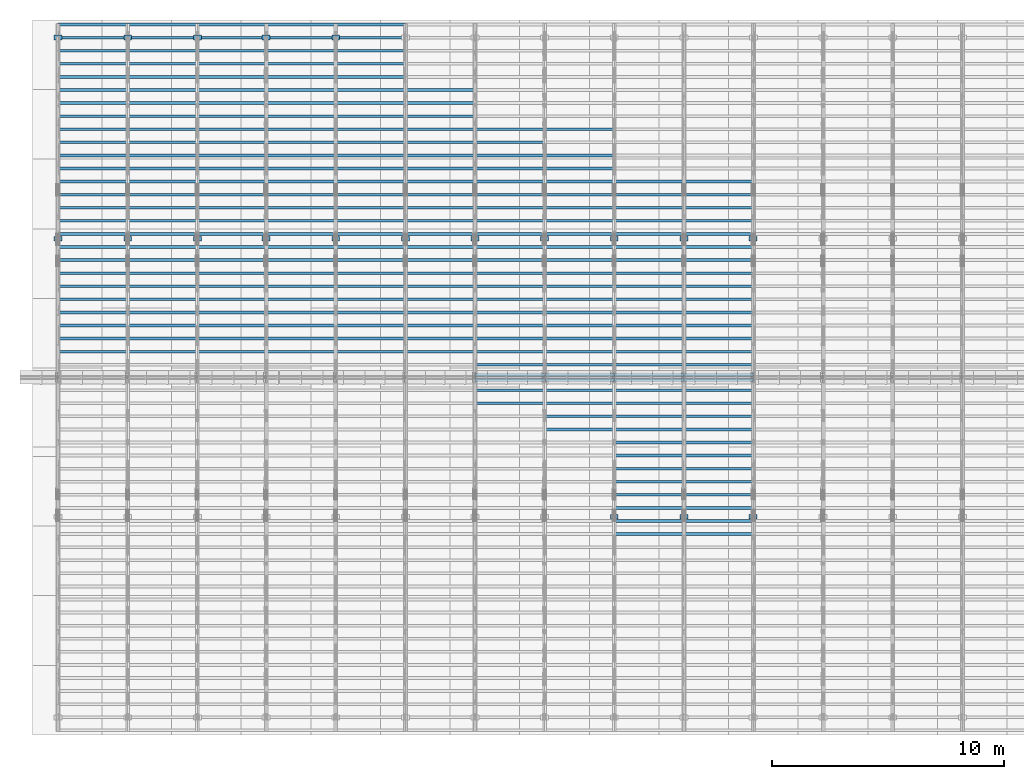
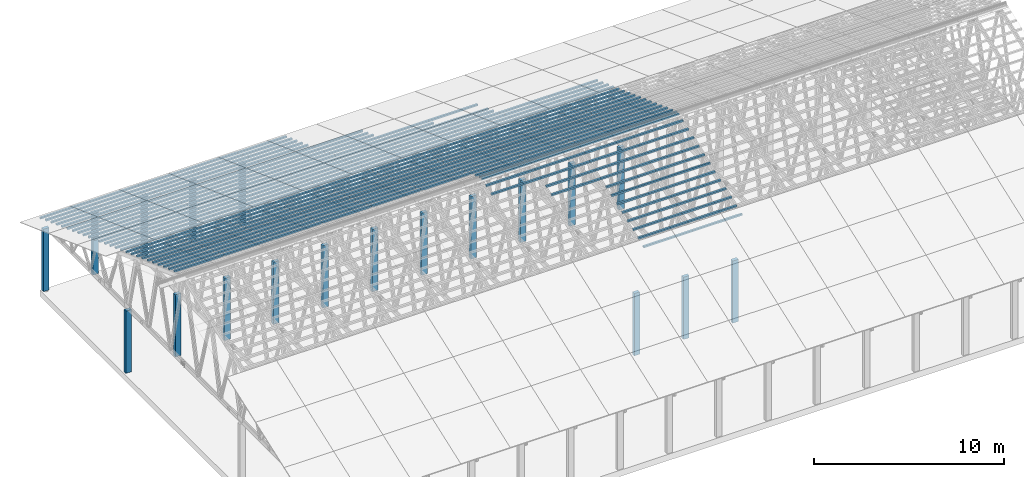
# One storey, part 2 of 189: 275 columns.
"""IFC2X3 building model written with IfcOpenShell, lengths in millimetres."""

from ifc_helpers import new_model, entity, si_unit, converted_unit, derived_unit, direction, frame, frame_2d, origin, origin_2d_with_axis, place, context, subcontext, project, spatial, rectangle, extrude, boolean, source, transform, mapped, material, type_object, type_shapes, element, save


model = new_model("IFC2X3")

# Units and contexts
model_context = context("Model", 3, precision=0.01, world=origin(), true_north=direction((6.12303176911189e-17, 1.0)))
body_context = subcontext(model_context, "Body", "Model", "MODEL_VIEW")
ifc_project = project(units=[si_unit("LENGTHUNIT", "METRE", prefix="MILLI"), si_unit("AREAUNIT", "SQUARE_METRE"), si_unit("VOLUMEUNIT", "CUBIC_METRE"), converted_unit("PLANEANGLEUNIT", "DEGREE", entity("IfcRatioMeasure", 0.0174532925199433), si_unit("PLANEANGLEUNIT", "RADIAN"), dimensions=[0, 0, 0, 0, 0, 0, 0]), si_unit("MASSUNIT", "GRAM", prefix="KILO"), derived_unit("MASSDENSITYUNIT", [(si_unit("MASSUNIT", "GRAM", prefix="KILO"), 1), (si_unit("LENGTHUNIT", "METRE"), -3)]), si_unit("TIMEUNIT", "SECOND"), si_unit("FREQUENCYUNIT", "HERTZ"), si_unit("THERMODYNAMICTEMPERATUREUNIT", "DEGREE_CELSIUS"), derived_unit("THERMALTRANSMITTANCEUNIT", [(si_unit("MASSUNIT", "GRAM", prefix="KILO"), 1), (si_unit("THERMODYNAMICTEMPERATUREUNIT", "KELVIN"), -1), (si_unit("TIMEUNIT", "SECOND"), -3)]), derived_unit("VOLUMETRICFLOWRATEUNIT", [(si_unit("LENGTHUNIT", "METRE"), 3), (si_unit("TIMEUNIT", "SECOND"), -1)]), si_unit("ELECTRICCURRENTUNIT", "AMPERE"), si_unit("ELECTRICVOLTAGEUNIT", "VOLT"), si_unit("POWERUNIT", "WATT"), si_unit("FORCEUNIT", "NEWTON"), si_unit("ILLUMINANCEUNIT", "LUX"), si_unit("LUMINOUSFLUXUNIT", "LUMEN"), si_unit("LUMINOUSINTENSITYUNIT", "CANDELA"), derived_unit("USERDEFINED", [(si_unit("MASSUNIT", "GRAM", prefix="KILO"), -1), (si_unit("LENGTHUNIT", "METRE"), -2), (si_unit("TIMEUNIT", "SECOND"), 3), (si_unit("LUMINOUSFLUXUNIT", "LUMEN"), 1)]), derived_unit("LINEARVELOCITYUNIT", [(si_unit("LENGTHUNIT", "METRE"), 1), (si_unit("TIMEUNIT", "SECOND"), -1)]), si_unit("PRESSUREUNIT", "PASCAL"), derived_unit("USERDEFINED", [(si_unit("LENGTHUNIT", "METRE"), -2), (si_unit("MASSUNIT", "GRAM", prefix="KILO"), 1), (si_unit("TIMEUNIT", "SECOND"), -2)])], contexts=[model_context])

# Site, building, storey
site_placement = place(None, origin())
site = spatial("IfcSite", under=ifc_project, at=site_placement, CompositionType="ELEMENT")
building_placement = place(site_placement, origin())
building = spatial("IfcBuilding", under=site, at=building_placement, CompositionType="ELEMENT")
storey_placement = place(building_placement, origin())
storey = spatial("IfcBuildingStorey", under=building, at=storey_placement, Name="Default", CompositionType="ELEMENT", Elevation=0.0)

# Columns
ifc_material_1 = material(Name="2")
column_type_1 = type_object("IfcColumnType", Name="100x70", PredefinedType="COLUMN")
shared_shape_1 = source(origin(), body_context, "Body", "CSG", [
    boolean("DIFFERENCE", extrude(rectangle(XDim=2998.26294985256, YDim=117.910672112436, at=frame_2d((0.0, -7.105427357601e-15), x_axis=(1.0, 0.0))), frame((1499.13147492628, 146.833369190677, -28.6286403914047)), (0.0, 0.0, 1.0), 99.9804977897746), extrude(rectangle(XDim=70.0000000018648, YDim=100.00000000027, at=frame_2d((3.5527136788005e-15, 3.5527136788005e-15), x_axis=(0.0, 1.0))), frame((2998.26294985256, 146.833369190677, 21.3616085034827), z_axis=(1.0, 0.0, 0.0), x_axis=(0.0, 0.939692620784201, -0.34202014333036)), (0.0, 0.0, -1.0), 2998.26294985256)),
])
type_shapes(column_type_1, [shared_shape_1])
for number, where, name in (
    (1, (27231.7370501475, 23042.7892953046, 2712.67421972394), "H_28_35_gradi:100x70"),
    (2, (27231.7370501475, 22478.973722833, 2917.88630571934), "H_28_35_gradi:100x70"),
    (3, (27231.7370501475, 21915.1581503615, 3123.09839171474), "H_28_35_gradi:100x70"),
    (4, (27231.7370501475, 21351.3425778899, 3328.31047771014), "H_28_35_gradi:100x70"),
    (5, (27231.7370501475, 20787.5270054184, 3533.52256370554), "H_28_35_gradi:100x70"),
    (6, (27231.7370501475, 20223.7114329468, 3738.73464970094), "H_28_35_gradi:100x70"),
    (7, (27231.7370501475, 19659.8958604753, 3943.94673569634), "H_28_35_gradi:100x70"),
    (8, (27231.7370501475, 19096.0802880037, 4149.15882169174), "H_28_35_gradi:100x70"),
    (9, (27231.7370501475, 18532.2647155322, 4354.37090768715), "H_28_35_gradi:100x70"),
    (10, (27231.7370501475, 17968.4491430607, 4559.58299368255), "H_28_35_gradi:100x70"),
    (11, (27231.7370501475, 17404.6335705891, 4764.79507967795), "H_28_35_gradi:100x70"),
    (12, (27231.7370501475, 16840.8179981176, 4970.00716567335), "H_28_35_gradi:100x70"),
    (13, (27231.7370501475, 16277.002425646, 5175.21925166875), "H_28_35_gradi:100x70"),
    (14, (27231.7370501475, 15713.1868531745, 5380.43133766415), "H_28_35_gradi:100x70"),
    (15, (27231.7370501475, 15149.3712807029, 5585.64342365955), "H_28_35_gradi:100x70"),
    (16, (27231.7370501475, 14712.1220107287, 5744.78914288479), "H_28_35_gradi:100x70"),
    (17, (24233.4741002949, 23042.7892953046, 2712.67421972394), "H_28_35_gradi:100x70"),
    (18, (24233.4741002949, 22478.973722833, 2917.88630571934), "H_28_35_gradi:100x70"),
    (19, (24233.4741002949, 21915.1581503615, 3123.09839171474), "H_28_35_gradi:100x70"),
    (20, (24233.4741002949, 21351.3425778899, 3328.31047771014), "H_28_35_gradi:100x70"),
    (21, (24233.4741002949, 20787.5270054184, 3533.52256370554), "H_28_35_gradi:100x70"),
    (22, (24233.4741002949, 20223.7114329468, 3738.73464970094), "H_28_35_gradi:100x70"),
    (23, (24233.4741002949, 19659.8958604753, 3943.94673569634), "H_28_35_gradi:100x70"),
    (24, (24233.4741002949, 19096.0802880037, 4149.15882169174), "H_28_35_gradi:100x70"),
    (25, (24233.4741002949, 18532.2647155322, 4354.37090768715), "H_28_35_gradi:100x70"),
    (26, (24233.4741002949, 17968.4491430607, 4559.58299368255), "H_28_35_gradi:100x70"),
    (27, (24233.4741002949, 17404.6335705891, 4764.79507967795), "H_28_35_gradi:100x70"),
    (28, (24233.4741002949, 16840.8179981176, 4970.00716567335), "H_28_35_gradi:100x70"),
    (29, (24233.4741002949, 16277.002425646, 5175.21925166875), "H_28_35_gradi:100x70"),
    (30, (24233.4741002949, 15713.1868531745, 5380.43133766415), "H_28_35_gradi:100x70"),
    (31, (24233.4741002949, 15149.3712807029, 5585.64342365955), "H_28_35_gradi:100x70"),
    (32, (24233.4741002949, 14712.1220107287, 5744.78914288479), "H_28_35_gradi:100x70"),
    (33, (21235.2111504423, 25298.0515851907, 1891.82587574233), "H_28_35_gradi:100x70"),
    (34, (21235.2111504423, 24170.4204402477, 2302.25004773314), "H_28_35_gradi:100x70"),
    (35, (21235.2111504423, 23606.6048677761, 2507.46213372854), "H_28_35_gradi:100x70"),
    (36, (21235.2111504423, 23042.7892953046, 2712.67421972394), "H_28_35_gradi:100x70"),
    (37, (21235.2111504423, 22478.973722833, 2917.88630571934), "H_28_35_gradi:100x70"),
    (38, (21235.2111504423, 21915.1581503615, 3123.09839171474), "H_28_35_gradi:100x70"),
    (39, (21235.2111504423, 21351.3425778899, 3328.31047771014), "H_28_35_gradi:100x70"),
    (40, (21235.2111504423, 20787.5270054184, 3533.52256370554), "H_28_35_gradi:100x70"),
    (41, (21235.2111504423, 20223.7114329469, 3738.73464970094), "H_28_35_gradi:100x70"),
    (42, (21235.2111504423, 19659.8958604753, 3943.94673569634), "H_28_35_gradi:100x70"),
    (43, (21235.2111504423, 19096.0802880038, 4149.15882169174), "H_28_35_gradi:100x70"),
    (44, (21235.2111504423, 18532.2647155322, 4354.37090768715), "H_28_35_gradi:100x70"),
    (45, (21235.2111504423, 17968.4491430607, 4559.58299368255), "H_28_35_gradi:100x70"),
    (46, (21235.2111504423, 17404.6335705891, 4764.79507967795), "H_28_35_gradi:100x70"),
    (47, (21235.2111504423, 16840.8179981176, 4970.00716567335), "H_28_35_gradi:100x70"),
    (48, (21235.2111504423, 16277.002425646, 5175.21925166875), "H_28_35_gradi:100x70"),
    (49, (21235.2111504423, 15713.1868531745, 5380.43133766415), "H_28_35_gradi:100x70"),
    (50, (21235.2111504423, 15149.3712807029, 5585.64342365955), "H_28_35_gradi:100x70"),
    (51, (21235.2111504423, 14712.1220107287, 5744.78914288479), "H_28_35_gradi:100x70"),
    (52, (18231.7370501475, 25298.0515851908, 1891.82587574233), "H_28_35_gradi:100x70"),
    (53, (18231.7370501475, 24734.2360127192, 2097.03796173773), "H_28_35_gradi:100x70"),
    (54, (18231.7370501475, 24170.4204402477, 2302.25004773314), "H_28_35_gradi:100x70"),
    (55, (18231.7370501475, 23606.6048677761, 2507.46213372854), "H_28_35_gradi:100x70"),
    (56, (18231.7370501475, 23042.7892953046, 2712.67421972394), "H_28_35_gradi:100x70"),
    (57, (18231.7370501475, 22478.973722833, 2917.88630571934), "H_28_35_gradi:100x70"),
    (58, (18231.7370501475, 21915.1581503615, 3123.09839171474), "H_28_35_gradi:100x70"),
    (59, (18231.7370501475, 21351.3425778899, 3328.31047771014), "H_28_35_gradi:100x70"),
    (60, (18231.7370501475, 20787.5270054184, 3533.52256370554), "H_28_35_gradi:100x70"),
    (61, (18231.7370501475, 20223.7114329469, 3738.73464970094), "H_28_35_gradi:100x70"),
    (62, (18231.7370501475, 19659.8958604753, 3943.94673569634), "H_28_35_gradi:100x70"),
    (63, (18231.7370501475, 19096.0802880038, 4149.15882169174), "H_28_35_gradi:100x70"),
    (64, (18231.7370501475, 18532.2647155322, 4354.37090768715), "H_28_35_gradi:100x70"),
    (65, (18231.7370501475, 17968.4491430607, 4559.58299368255), "H_28_35_gradi:100x70"),
    (66, (18231.7370501475, 17404.6335705891, 4764.79507967795), "H_28_35_gradi:100x70"),
    (67, (18231.7370501475, 16840.8179981176, 4970.00716567335), "H_28_35_gradi:100x70"),
    (68, (18231.7370501475, 16277.002425646, 5175.21925166875), "H_28_35_gradi:100x70"),
    (69, (18231.7370501475, 15713.1868531745, 5380.43133766415), "H_28_35_gradi:100x70"),
    (70, (18231.7370501475, 15149.371280703, 5585.64342365955), "H_28_35_gradi:100x70"),
    (71, (18231.7370501475, 14712.1220107287, 5744.78914288479), "H_28_35_gradi:100x70"),
    (72, (15233.4741002949, 26989.4983026054, 1276.18961775613), "H_28_35_gradi:100x70"),
    (73, (15233.4741002949, 26425.6827301339, 1481.40170375153), "H_28_35_gradi:100x70"),
    (74, (15233.4741002949, 25861.8671576623, 1686.61378974693), "H_28_35_gradi:100x70"),
    (75, (15233.4741002949, 25298.0515851908, 1891.82587574233), "H_28_35_gradi:100x70"),
    (76, (15233.4741002949, 24734.2360127192, 2097.03796173773), "H_28_35_gradi:100x70"),
    (77, (15233.4741002949, 24170.4204402477, 2302.25004773314), "H_28_35_gradi:100x70"),
    (78, (15233.4741002949, 23606.6048677761, 2507.46213372854), "H_28_35_gradi:100x70"),
    (79, (15233.4741002949, 23042.7892953046, 2712.67421972394), "H_28_35_gradi:100x70"),
    (80, (15233.4741002949, 22478.973722833, 2917.88630571934), "H_28_35_gradi:100x70"),
    (81, (15233.4741002949, 21915.1581503615, 3123.09839171474), "H_28_35_gradi:100x70"),
    (82, (15233.4741002949, 21351.34257789, 3328.31047771014), "H_28_35_gradi:100x70"),
    (83, (15233.4741002949, 20787.5270054184, 3533.52256370554), "H_28_35_gradi:100x70"),
    (84, (15233.4741002949, 20223.7114329469, 3738.73464970094), "H_28_35_gradi:100x70"),
    (85, (15233.4741002949, 19659.8958604753, 3943.94673569634), "H_28_35_gradi:100x70"),
    (86, (15233.4741002949, 19096.0802880038, 4149.15882169174), "H_28_35_gradi:100x70"),
    (87, (15233.4741002949, 18532.2647155322, 4354.37090768715), "H_28_35_gradi:100x70"),
    (88, (15233.4741002949, 17968.4491430607, 4559.58299368255), "H_28_35_gradi:100x70"),
    (89, (15233.4741002949, 17404.6335705891, 4764.79507967795), "H_28_35_gradi:100x70"),
    (90, (15233.4741002949, 16840.8179981176, 4970.00716567335), "H_28_35_gradi:100x70"),
    (91, (15233.4741002949, 16277.0024256461, 5175.21925166875), "H_28_35_gradi:100x70"),
    (92, (15233.4741002949, 15713.1868531745, 5380.43133766415), "H_28_35_gradi:100x70"),
    (93, (12231.7370501475, 29808.5761649638, 250.129187781087), "H_28_35_gradi:100x70"),
    (94, (12231.7370501475, 29244.7605924923, 455.341273776488), "H_28_35_gradi:100x70"),
    (95, (12231.7370501475, 28680.94502002, 660.553359769929), "H_28_35_gradi:100x70"),
    (96, (12231.7370501475, 28117.1294475485, 865.765445765329), "H_28_35_gradi:100x70"),
    (97, (12231.7370501475, 27553.3138750769, 1070.97753176073), "H_28_35_gradi:100x70"),
    (98, (12231.7370501475, 26989.4983026054, 1276.18961775613), "H_28_35_gradi:100x70"),
    (99, (12231.7370501475, 26425.6827301339, 1481.40170375153), "H_28_35_gradi:100x70"),
    (100, (12231.7370501475, 25861.8671576623, 1686.61378974693), "H_28_35_gradi:100x70"),
    (101, (12231.7370501475, 25298.0515851908, 1891.82587574233), "H_28_35_gradi:100x70"),
    (102, (12231.7370501475, 24734.2360127192, 2097.03796173773), "H_28_35_gradi:100x70"),
    (103, (12231.7370501475, 24170.4204402477, 2302.25004773314), "H_28_35_gradi:100x70"),
    (104, (12231.7370501475, 23606.6048677761, 2507.46213372854), "H_28_35_gradi:100x70"),
    (105, (12231.7370501475, 23042.7892953046, 2712.67421972394), "H_28_35_gradi:100x70"),
    (106, (12231.7370501475, 22478.9737228331, 2917.88630571934), "H_28_35_gradi:100x70"),
    (107, (12231.7370501475, 21915.1581503615, 3123.09839171474), "H_28_35_gradi:100x70"),
    (108, (12231.7370501475, 21351.34257789, 3328.31047771014), "H_28_35_gradi:100x70"),
    (109, (12231.7370501475, 20787.5270054184, 3533.52256370554), "H_28_35_gradi:100x70"),
    (110, (12231.7370501475, 20223.7114329469, 3738.73464970094), "H_28_35_gradi:100x70"),
    (111, (12231.7370501475, 19659.8958604753, 3943.94673569634), "H_28_35_gradi:100x70"),
    (112, (12231.7370501475, 19096.0802880038, 4149.15882169174), "H_28_35_gradi:100x70"),
    (113, (12231.7370501475, 18532.2647155322, 4354.37090768715), "H_28_35_gradi:100x70"),
    (114, (12231.7370501475, 17968.4491430607, 4559.58299368255), "H_28_35_gradi:100x70"),
    (115, (12231.7370501475, 17404.6335705892, 4764.79507967795), "H_28_35_gradi:100x70"),
    (116, (12231.7370501475, 16840.8179981176, 4970.00716567335), "H_28_35_gradi:100x70"),
    (117, (12231.7370501475, 16277.0024256461, 5175.21925166875), "H_28_35_gradi:100x70"),
    (118, (12231.7370501475, 15713.1868531745, 5380.43133766415), "H_28_35_gradi:100x70"),
    (119, (9233.47410029491, 29808.5761649638, 250.129187781087), "H_28_35_gradi:100x70"),
    (120, (9233.47410029491, 29244.7605924923, 455.341273776488), "H_28_35_gradi:100x70"),
    (121, (9233.47410029491, 28680.94502002, 660.553359769929), "H_28_35_gradi:100x70"),
    (122, (9233.47410029491, 28117.1294475485, 865.765445765329), "H_28_35_gradi:100x70"),
    (123, (9233.47410029491, 27553.313875077, 1070.97753176073), "H_28_35_gradi:100x70"),
    (124, (9233.47410029491, 26989.4983026054, 1276.18961775613), "H_28_35_gradi:100x70"),
    (125, (9233.47410029491, 26425.6827301339, 1481.40170375153), "H_28_35_gradi:100x70"),
    (126, (9233.47410029491, 25861.8671576623, 1686.61378974693), "H_28_35_gradi:100x70"),
    (127, (9233.47410029491, 25298.0515851908, 1891.82587574233), "H_28_35_gradi:100x70"),
    (128, (9233.47410029491, 24734.2360127192, 2097.03796173773), "H_28_35_gradi:100x70"),
    (129, (9233.47410029491, 24170.4204402477, 2302.25004773314), "H_28_35_gradi:100x70"),
    (130, (9233.47410029491, 23606.6048677762, 2507.46213372854), "H_28_35_gradi:100x70"),
    (131, (9233.47410029491, 23042.7892953046, 2712.67421972394), "H_28_35_gradi:100x70"),
    (132, (9233.47410029491, 22478.9737228331, 2917.88630571934), "H_28_35_gradi:100x70"),
    (133, (9233.47410029491, 21915.1581503615, 3123.09839171474), "H_28_35_gradi:100x70"),
    (134, (9233.47410029491, 21351.34257789, 3328.31047771014), "H_28_35_gradi:100x70"),
    (135, (9233.47410029491, 20787.5270054184, 3533.52256370554), "H_28_35_gradi:100x70"),
    (136, (9233.47410029491, 20223.7114329469, 3738.73464970094), "H_28_35_gradi:100x70"),
    (137, (9233.47410029491, 19659.8958604753, 3943.94673569634), "H_28_35_gradi:100x70"),
    (138, (9233.47410029491, 19096.0802880038, 4149.15882169174), "H_28_35_gradi:100x70"),
    (139, (9233.47410029491, 18532.2647155322, 4354.37090768715), "H_28_35_gradi:100x70"),
    (140, (9233.47410029491, 17968.4491430607, 4559.58299368255), "H_28_35_gradi:100x70"),
    (141, (9233.47410029491, 17404.6335705892, 4764.79507967795), "H_28_35_gradi:100x70"),
    (142, (9233.47410029491, 16840.8179981176, 4970.00716567335), "H_28_35_gradi:100x70"),
    (143, (9233.47410029491, 16277.0024256461, 5175.21925166875), "H_28_35_gradi:100x70"),
    (144, (9233.47410029491, 15713.1868531745, 5380.43133766415), "H_28_35_gradi:100x70"),
    (145, (6235.21115044234, 29808.5761649639, 250.129187781087), "H_28_35_gradi:100x70"),
    (146, (6235.21115044234, 29244.7605924923, 455.341273776488), "H_28_35_gradi:100x70"),
    (147, (6235.21115044234, 28680.94502002, 660.553359769929), "H_28_35_gradi:100x70"),
    (148, (6235.21115044234, 28117.1294475485, 865.765445765329), "H_28_35_gradi:100x70"),
    (149, (6235.21115044234, 27553.313875077, 1070.97753176073), "H_28_35_gradi:100x70"),
    (150, (6235.21115044234, 26989.4983026054, 1276.18961775613), "H_28_35_gradi:100x70"),
    (151, (6235.21115044234, 26425.6827301339, 1481.40170375153), "H_28_35_gradi:100x70"),
    (152, (6235.21115044234, 25861.8671576623, 1686.61378974693), "H_28_35_gradi:100x70"),
    (153, (6235.21115044234, 25298.0515851908, 1891.82587574233), "H_28_35_gradi:100x70"),
    (154, (6235.21115044234, 24734.2360127192, 2097.03796173773), "H_28_35_gradi:100x70"),
    (155, (6235.21115044234, 24170.4204402477, 2302.25004773314), "H_28_35_gradi:100x70"),
    (156, (6235.21115044234, 23606.6048677762, 2507.46213372854), "H_28_35_gradi:100x70"),
    (157, (6235.21115044234, 23042.7892953046, 2712.67421972394), "H_28_35_gradi:100x70"),
    (158, (6235.21115044234, 22478.9737228331, 2917.88630571934), "H_28_35_gradi:100x70"),
    (159, (6235.21115044234, 21915.1581503615, 3123.09839171474), "H_28_35_gradi:100x70"),
    (160, (6235.21115044234, 21351.34257789, 3328.31047771014), "H_28_35_gradi:100x70"),
    (161, (6235.21115044234, 20787.5270054184, 3533.52256370554), "H_28_35_gradi:100x70"),
    (162, (6235.21115044234, 20223.7114329469, 3738.73464970094), "H_28_35_gradi:100x70"),
    (163, (6235.21115044234, 19659.8958604753, 3943.94673569634), "H_28_35_gradi:100x70"),
    (164, (6235.21115044234, 19096.0802880038, 4149.15882169174), "H_28_35_gradi:100x70"),
    (165, (6235.21115044234, 18532.2647155323, 4354.37090768715), "H_28_35_gradi:100x70"),
    (166, (6235.21115044234, 17968.4491430607, 4559.58299368255), "H_28_35_gradi:100x70"),
    (167, (6235.21115044234, 17404.6335705892, 4764.79507967795), "H_28_35_gradi:100x70"),
    (168, (6235.21115044234, 16840.8179981176, 4970.00716567335), "H_28_35_gradi:100x70"),
    (169, (6235.21115044234, 16277.0024256461, 5175.21925166875), "H_28_35_gradi:100x70"),
    (170, (6235.21115044234, 15713.1868531745, 5380.43133766415), "H_28_35_gradi:100x70"),
    (171, (3266.73705014749, 29808.5761649639, 250.129187781087), "H_28_35_gradi:100x70"),
    (172, (3266.73705014749, 29244.7605924923, 455.341273776488), "H_28_35_gradi:100x70"),
    (173, (3266.73705014749, 28680.9450200201, 660.553359769929), "H_28_35_gradi:100x70"),
    (174, (3266.73705014749, 28117.1294475485, 865.765445765329), "H_28_35_gradi:100x70"),
    (175, (3266.73705014749, 27553.313875077, 1070.97753176073), "H_28_35_gradi:100x70"),
    (176, (3266.73705014749, 26989.4983026054, 1276.18961775613), "H_28_35_gradi:100x70"),
    (177, (3266.73705014749, 26425.6827301339, 1481.40170375153), "H_28_35_gradi:100x70"),
    (178, (3266.73705014749, 25861.8671576623, 1686.61378974693), "H_28_35_gradi:100x70"),
    (179, (3266.73705014749, 25298.0515851908, 1891.82587574233), "H_28_35_gradi:100x70"),
    (180, (3266.73705014749, 24734.2360127193, 2097.03796173773), "H_28_35_gradi:100x70"),
    (181, (3266.73705014749, 24170.4204402477, 2302.25004773314), "H_28_35_gradi:100x70"),
    (182, (3266.73705014749, 23606.6048677762, 2507.46213372854), "H_28_35_gradi:100x70"),
    (183, (3266.73705014749, 23042.7892953046, 2712.67421972394), "H_28_35_gradi:100x70"),
    (184, (3266.73705014749, 22478.9737228331, 2917.88630571934), "H_28_35_gradi:100x70"),
    (185, (3266.73705014749, 21915.1581503615, 3123.09839171474), "H_28_35_gradi:100x70"),
    (186, (3266.73705014749, 21351.34257789, 3328.31047771014), "H_28_35_gradi:100x70"),
    (187, (3266.73705014749, 20787.5270054184, 3533.52256370554), "H_28_35_gradi:100x70"),
    (188, (3266.73705014749, 20223.7114329469, 3738.73464970094), "H_28_35_gradi:100x70"),
    (189, (3266.73705014749, 19659.8958604754, 3943.94673569634), "H_28_35_gradi:100x70"),
    (190, (3266.73705014749, 19096.0802880038, 4149.15882169174), "H_28_35_gradi:100x70"),
    (191, (3266.73705014749, 18532.2647155323, 4354.37090768715), "H_28_35_gradi:100x70"),
    (192, (3266.73705014749, 17968.4491430607, 4559.58299368255), "H_28_35_gradi:100x70"),
    (193, (3266.73705014749, 17404.6335705892, 4764.79507967795), "H_28_35_gradi:100x70"),
    (194, (3266.73705014749, 16840.8179981176, 4970.00716567335), "H_28_35_gradi:100x70"),
    (195, (3266.73705014749, 16277.0024256461, 5175.21925166875), "H_28_35_gradi:100x70"),
    (196, (3266.73705014749, 15713.1868531745, 5380.43133766415), "H_28_35_gradi:100x70"),
    (197, (268.474100294913, 29808.5761649639, 250.129187781087), "H_28_35_gradi:100x70"),
    (198, (268.474100294913, 29244.7605924923, 455.341273776488), "H_28_35_gradi:100x70"),
    (199, (268.474100294913, 28680.9450200201, 660.553359769929), "H_28_35_gradi:100x70"),
    (200, (268.474100294913, 28117.1294475485, 865.765445765329), "H_28_35_gradi:100x70"),
    (201, (268.474100294913, 27553.313875077, 1070.97753176073), "H_28_35_gradi:100x70"),
    (202, (268.474100294913, 26989.4983026054, 1276.18961775613), "H_28_35_gradi:100x70"),
    (203, (268.474100294913, 26425.6827301339, 1481.40170375153), "H_28_35_gradi:100x70"),
    (204, (268.474100294913, 25861.8671576623, 1686.61378974693), "H_28_35_gradi:100x70"),
    (205, (268.474100294913, 25298.0515851908, 1891.82587574233), "H_28_35_gradi:100x70"),
    (206, (268.474100294913, 24734.2360127193, 2097.03796173773), "H_28_35_gradi:100x70"),
    (207, (268.474100294913, 24170.4204402477, 2302.25004773314), "H_28_35_gradi:100x70"),
    (208, (268.474100294913, 23606.6048677762, 2507.46213372854), "H_28_35_gradi:100x70"),
    (209, (268.474100294913, 23042.7892953046, 2712.67421972394), "H_28_35_gradi:100x70"),
    (210, (268.474100294913, 22478.9737228331, 2917.88630571934), "H_28_35_gradi:100x70"),
    (211, (268.474100294913, 21915.1581503615, 3123.09839171474), "H_28_35_gradi:100x70"),
    (212, (268.474100294913, 21351.34257789, 3328.31047771014), "H_28_35_gradi:100x70"),
    (213, (268.474100294913, 20787.5270054185, 3533.52256370554), "H_28_35_gradi:100x70"),
    (214, (268.474100294913, 20223.7114329469, 3738.73464970094), "H_28_35_gradi:100x70"),
    (215, (268.474100294913, 19659.8958604754, 3943.94673569634), "H_28_35_gradi:100x70"),
    (216, (268.474100294913, 19096.0802880038, 4149.15882169174), "H_28_35_gradi:100x70"),
    (217, (268.474100294913, 18532.2647155323, 4354.37090768715), "H_28_35_gradi:100x70"),
    (218, (268.474100294913, 17968.4491430607, 4559.58299368255), "H_28_35_gradi:100x70"),
    (219, (268.474100294913, 17404.6335705892, 4764.79507967795), "H_28_35_gradi:100x70"),
    (220, (268.474100294913, 16840.8179981176, 4970.00716567335), "H_28_35_gradi:100x70"),
    (221, (268.474100294913, 16277.0024256461, 5175.21925166875), "H_28_35_gradi:100x70"),
    (222, (268.474100294913, 15713.1868531745, 5380.43133766415), "H_28_35_gradi:100x70"),
):
    element("IfcColumn", number, at=place(storey_placement, frame(where)), inside=storey, type_object=column_type_1, material=ifc_material_1, Name=name, ObjectType="H_28_35_gradi:100x70", context=body_context, shape_type="MappedRepresentation", body=[
        mapped(shared_shape_1, transform((0.0, 0.0, 0.0), scale=1.0)),
    ])
column_type_2 = type_object("IfcColumnType", Name="100x70", PredefinedType="COLUMN")
shared_shape_2 = source(origin(), body_context, "Body", "CSG", [
    boolean("DIFFERENCE", extrude(rectangle(XDim=2998.26294985257, YDim=117.910672112436, at=frame_2d((0.0, 7.105427357601e-15), x_axis=(1.0, 0.0))), frame((1499.13147492629, -146.833369190677, -28.6286403914047)), (0.0, 0.0, 1.0), 99.9804977897746), extrude(rectangle(XDim=70.0000000018648, YDim=100.00000000027, at=frame_2d((3.5527136788005e-15, 3.5527136788005e-15), x_axis=(0.0, 1.0))), frame((0.0, -146.833369190677, 21.3616085034827), z_axis=(-1.0, 0.0, 0.0), x_axis=(0.0, -0.939692620784201, -0.34202014333036)), (0.0, 0.0, -1.0), 2998.26294985257)),
])
type_shapes(column_type_2, [shared_shape_2])
for number, where, name in (
    (223, (27231.7370501475, 8148.65750983633, 3328.31047771014), "H_28_35_gradi:100x70"),
    (224, (27231.7370501475, 8712.47308230788, 3533.52256370554), "H_28_35_gradi:100x70"),
    (225, (27231.7370501475, 9276.28865477942, 3738.73464970094), "H_28_35_gradi:100x70"),
    (226, (27231.7370501475, 9840.10422725096, 3943.94673569634), "H_28_35_gradi:100x70"),
    (227, (27231.7370501475, 10403.9197997225, 4149.15882169174), "H_28_35_gradi:100x70"),
    (228, (27231.7370501475, 10967.7353721941, 4354.37090768715), "H_28_35_gradi:100x70"),
    (229, (27231.7370501475, 11531.5509446656, 4559.58299368255), "H_28_35_gradi:100x70"),
    (230, (27231.7370501475, 12095.3665171371, 4764.79507967795), "H_28_35_gradi:100x70"),
    (231, (27231.7370501475, 12659.1820896087, 4970.00716567335), "H_28_35_gradi:100x70"),
    (232, (27231.7370501475, 13222.9976620802, 5175.21925166875), "H_28_35_gradi:100x70"),
    (233, (27231.7370501475, 13786.8132345518, 5380.43133766415), "H_28_35_gradi:100x70"),
    (234, (27231.7370501475, 14350.6288070233, 5585.64342365955), "H_28_35_gradi:100x70"),
    (235, (27231.7370501475, 14787.8780769975, 5744.78914288479), "H_28_35_gradi:100x70"),
    (236, (24233.4741002949, 8148.65750983634, 3328.31047771014), "H_28_35_gradi:100x70"),
    (237, (24233.4741002949, 8712.47308230789, 3533.52256370554), "H_28_35_gradi:100x70"),
    (238, (24233.4741002949, 9276.28865477943, 3738.73464970094), "H_28_35_gradi:100x70"),
    (239, (24233.4741002949, 9840.10422725097, 3943.94673569634), "H_28_35_gradi:100x70"),
    (240, (24233.4741002949, 10403.9197997225, 4149.15882169174), "H_28_35_gradi:100x70"),
    (241, (24233.4741002949, 10967.7353721941, 4354.37090768715), "H_28_35_gradi:100x70"),
    (242, (24233.4741002949, 11531.5509446656, 4559.58299368255), "H_28_35_gradi:100x70"),
    (243, (24233.4741002949, 12095.3665171371, 4764.79507967795), "H_28_35_gradi:100x70"),
    (244, (24233.4741002949, 12659.1820896087, 4970.00716567335), "H_28_35_gradi:100x70"),
    (245, (24233.4741002949, 13222.9976620802, 5175.21925166875), "H_28_35_gradi:100x70"),
    (246, (24233.4741002949, 13786.8132345518, 5380.43133766415), "H_28_35_gradi:100x70"),
    (247, (24233.4741002949, 14350.6288070233, 5585.64342365955), "H_28_35_gradi:100x70"),
    (248, (24233.4741002949, 14787.8780769975, 5744.78914288479), "H_28_35_gradi:100x70"),
    (249, (21235.2111504423, 12659.1820896087, 4970.00716567335), "H_28_35_gradi:100x70"),
    (250, (21235.2111504423, 13222.9976620802, 5175.21925166875), "H_28_35_gradi:100x70"),
    (251, (21235.2111504423, 13786.8132345518, 5380.43133766415), "H_28_35_gradi:100x70"),
    (252, (21235.2111504423, 14350.6288070233, 5585.64342365955), "H_28_35_gradi:100x70"),
    (253, (21235.2111504423, 14787.8780769976, 5744.78914288479), "H_28_35_gradi:100x70"),
    (254, (18231.7370501475, 13786.8132345518, 5380.43133766415), "H_28_35_gradi:100x70"),
    (255, (18231.7370501475, 14350.6288070233, 5585.64342365955), "H_28_35_gradi:100x70"),
    (256, (18231.7370501475, 14787.8780769976, 5744.78914288479), "H_28_35_gradi:100x70"),
):
    element("IfcColumn", number, at=place(storey_placement, frame(where)), inside=storey, type_object=column_type_2, material=ifc_material_1, Name=name, ObjectType="H_28_35_gradi:100x70", context=body_context, shape_type="MappedRepresentation", body=[
        mapped(shared_shape_2, transform((0.0, 0.0, 0.0), scale=1.0)),
    ])
ifc_material_2 = material()
column_type_3 = type_object("IfcColumnType", Name="200x200", PredefinedType="COLUMN")
shared_shape_3 = source(origin(), body_context, "Body", "SweptSolid", [
    extrude(rectangle(XDim=339.999999999998, YDim=200.000000000004, at=origin_2d_with_axis()), frame((100.0, 280.0, -4000.0), z_axis=(0.0, 0.0, 1.0), x_axis=(0.0, -1.0, 0.0)), (0.0, 0.0, 1.0), 4000.0),
])
type_shapes(column_type_3, [shared_shape_3])
for number, where, z_axis, x_axis, name in (
    (257, (30490.0, 8650.0, 0.0), (0.0, 0.0, 1.0), (0.0, 1.0, 0.0), "V:200x200"),
    (258, (27510.0, 8650.0, 0.0), (0.0, 0.0, 1.0), (0.0, 1.0, 0.0), "V:200x200"),
    (259, (24510.0, 8650.0, 0.0), (0.0, 0.0, 1.0), (0.0, 1.0, 0.0), "V:200x200"),
    (260, (30490.0, 20629.6217832149, 0.0), (0.0, 0.0, 1.0), (0.0, 1.0, 0.0), "V:200x200"),
    (261, (27510.0, 20629.6217832149, 0.0), (0.0, 0.0, 1.0), (0.0, 1.0, 0.0), "V:200x200"),
    (262, (24510.0, 20629.6217832149, 0.0), (0.0, 0.0, 1.0), (0.0, 1.0, 0.0), "V:200x200"),
    (263, (21510.0, 20629.621783215, 0.0), (0.0, 0.0, 1.0), (0.0, 1.0, 0.0), "V:200x200"),
    (264, (18510.0, 20629.621783215, 0.0), (0.0, 0.0, 1.0), (0.0, 1.0, 0.0), "V:200x200"),
    (265, (15510.0, 20629.621783215, 0.0), (0.0, 0.0, 1.0), (0.0, 1.0, 0.0), "V:200x200"),
    (266, (12510.0, 20629.621783215, 0.0), (0.0, 0.0, 1.0), (0.0, 1.0, 0.0), "V:200x200"),
    (267, (9510.0, 20629.621783215, 0.0), (0.0, 0.0, 1.0), (0.0, 1.0, 0.0), "V:200x200"),
    (268, (6545.0, 20629.621783215, 0.0), (0.0, 0.0, 1.0), (0.0, 1.0, 0.0), "V:200x200"),
    (269, (3545.0, 20629.621783215, 0.0), (0.0, 0.0, 1.0), (0.0, 1.0, 0.0), "V:200x200"),
    (270, (545.0, 20629.621783215, 0.0), (0.0, 0.0, 1.0), (0.0, 1.0, 0.0), "V:200x200"),
    (271, (12510.0, 29300.0, 0.0), (0.0, 0.0, 1.0), (0.0, 1.0, 0.0), "V:200x200"),
    (272, (9510.0, 29300.0, 0.0), (0.0, 0.0, 1.0), (0.0, 1.0, 0.0), "V:200x200"),
    (273, (6545.0, 29300.0, 0.0), (0.0, 0.0, 1.0), (0.0, 1.0, 0.0), "V:200x200"),
    (274, (3545.0, 29300.0, 0.0), (0.0, 0.0, 1.0), (0.0, 1.0, 0.0), "V:200x200"),
    (275, (545.0, 29300.0, 0.0), (0.0, 0.0, 1.0), (0.0, 1.0, 0.0), "V:200x200"),
):
    element("IfcColumn", number, at=place(storey_placement, frame(where, z_axis=z_axis, x_axis=x_axis)), inside=storey, type_object=column_type_3, material=ifc_material_2, Name=name, ObjectType="V:200x200", context=body_context, shape_type="MappedRepresentation", body=[
        mapped(shared_shape_3, transform((0.0, 0.0, 0.0), scale=1.0)),
    ])

save(model, "model.ifc")
